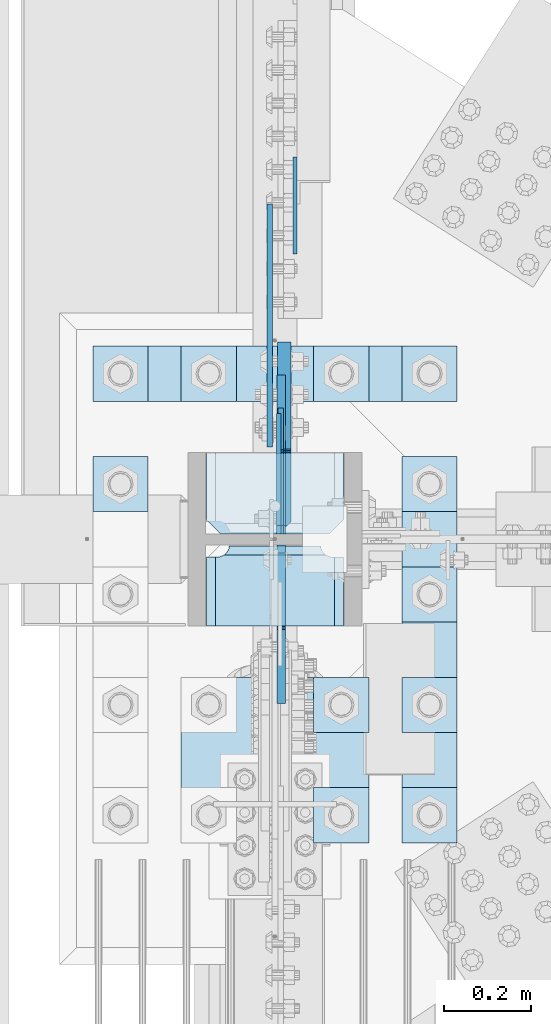
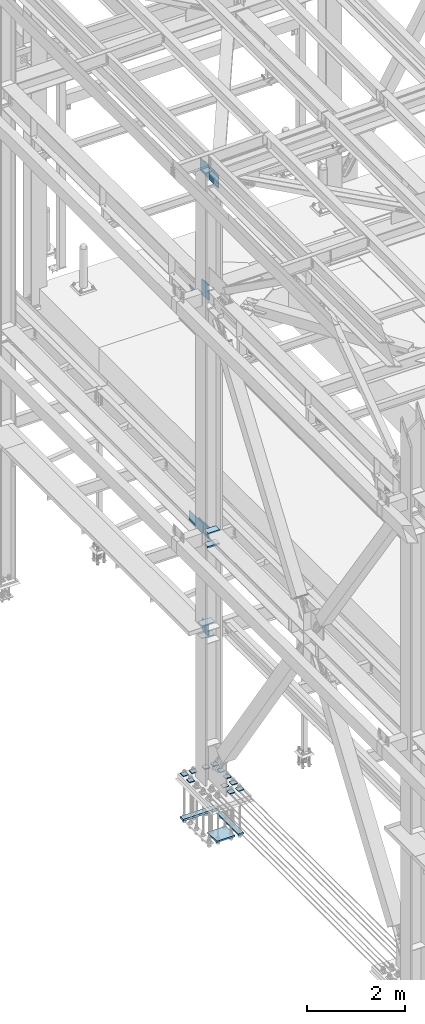
# One storey, part 3365 of 3843: 25 plates, 4 elements without a shape of their own.
"""IFC2X3 building model written with IfcOpenShell, lengths in millimetres."""

from ifc_helpers import new_model, si_unit, frame, origin_with_axes, place, context, subcontext, project, spatial, faceted_brep, material, type_object, element, aggregate, save


model = new_model("IFC2X3")

# Units and contexts
model_context = context("Model", 3, precision=1e-05, world=origin_with_axes())
body_context = subcontext(model_context, "Body", "Model", "MODEL_VIEW")
ifc_project = project(units=[si_unit("LENGTHUNIT", "METRE", prefix="MILLI"), si_unit("AREAUNIT", "SQUARE_METRE"), si_unit("VOLUMEUNIT", "CUBIC_METRE"), si_unit("MASSUNIT", "GRAM", prefix="KILO"), si_unit("TIMEUNIT", "SECOND"), si_unit("PLANEANGLEUNIT", "RADIAN"), si_unit("SOLIDANGLEUNIT", "STERADIAN"), si_unit("THERMODYNAMICTEMPERATUREUNIT", "DEGREE_CELSIUS"), si_unit("LUMINOUSINTENSITYUNIT", "LUMEN")], contexts=[model_context])

# Site, building, storey
site_placement = place(None, origin_with_axes())
site = spatial("IfcSite", under=ifc_project, at=site_placement, CompositionType="ELEMENT")
building_placement = place(site_placement, origin_with_axes())
building = spatial("IfcBuilding", under=site, at=building_placement, Name="Undefined", CompositionType="ELEMENT")
storey_placement = place(building_placement, origin_with_axes())
storey = spatial("IfcBuildingStorey", under=building, at=storey_placement, Name="Undefined", CompositionType="ELEMENT", Elevation=0.0)

# Assembly, plates
assembly_1_placement = place(storey_placement, origin_with_axes())
assembly_1 = element("IfcElementAssembly", 1, at=assembly_1_placement, inside=storey, Name="COLUMN", AssemblyPlace="NOTDEFINED", PredefinedType="RIGID_FRAME")
ifc_material = material(Name="STEEL/A572-50")
plate_type_1 = type_object("IfcPlateType", PredefinedType="NOTDEFINED")
plate_1_placement = place(assembly_1_placement, frame((36734.75, 75825.35, 33688.3375), z_axis=(-1.0, 0.0, 0.0), x_axis=(0.0, -1.0, 0.0)))
plate_1 = element("IfcPlate", 2, at=plate_1_placement, type_object=plate_type_1, material=ifc_material, Name="PLATE", context=body_context, shape_type="Brep", body=[
    faceted_brep([(0.0, -4.76249999999709, 0.0), (0.0, -4.76249999785796, 317.500000005042), (0.0, 4.76250000210712, 317.50000000505), (0.0, 4.76249999999709, 0.0), (150.81249847413, -4.76249999999709, 317.5), (150.81249847413, 4.76249999999709, 317.5), (184.150000000009, -4.76249999999709, 284.162498474121), (184.150000000009, 4.76249999999709, 284.162498474121), (184.150000000009, -4.76249999999709, 33.3375015258789), (184.150000000009, 4.76249999999709, 33.3375015258789), (150.81249847413, -4.76249999999709, 0.0), (150.81249847413, 4.76249999999709, 0.0)], [[[0, 1, 2, 3]], [[1, 4, 5, 2]], [[4, 6, 7, 5]], [[6, 8, 9, 7]], [[8, 10, 11, 9]], [[10, 0, 3, 11]], [[5, 7, 9, 11, 3, 2]], [[10, 8, 6, 4, 1, 0]]]),
])
plate_2_placement = place(assembly_1_placement, frame((36734.75, 75825.35, 34002.6625), z_axis=(-1.0, 0.0, 0.0), x_axis=(0.0, -1.0, 0.0)))
plate_2 = element("IfcPlate", 3, at=plate_2_placement, type_object=plate_type_1, material=ifc_material, Name="PLATE", context=body_context, shape_type="Brep", body=[
    faceted_brep([(0.0, -4.76249999999709, 0.0), (0.0, -4.76249999785796, 317.500000005042), (0.0, 4.76250000210712, 317.50000000505), (0.0, 4.76249999999709, 0.0), (150.81249847413, -4.76249999999709, 317.5), (150.81249847413, 4.76249999999709, 317.5), (184.150000000009, -4.76249999999709, 284.162498474121), (184.150000000009, 4.76249999999709, 284.162498474121), (184.150000000009, -4.76249999999709, 33.3375015258789), (184.150000000009, 4.76249999999709, 33.3375015258789), (150.81249847413, -4.76249999999709, 0.0), (150.81249847413, 4.76249999999709, 0.0)], [[[0, 1, 2, 3]], [[1, 4, 5, 2]], [[4, 6, 7, 5]], [[6, 8, 9, 7]], [[8, 10, 11, 9]], [[10, 0, 3, 11]], [[5, 7, 9, 11, 3, 2]], [[10, 8, 6, 4, 1, 0]]]),
])
plate_type_2 = type_object("IfcPlateType", PredefinedType="NOTDEFINED")
plate_3_placement = place(assembly_1_placement, frame((36588.7000000954, 75641.2, 42049.7), z_axis=(0.0, 0.707106781186548, 0.707106781186548), x_axis=(5.70000238222118e-08, 0.707106781186546, -0.707106781186546)))
plate_3 = element("IfcPlate", 4, at=plate_3_placement, type_object=plate_type_2, material=ifc_material, Name="PLATE", context=body_context, shape_type="Brep", body=[
    faceted_brep([(0.0, -6.3499999046162, 0.0), (-258.182363479495, -6.34999999999854, 258.182363479486), (-258.182363479495, 6.34999999999854, 258.182363479486), (7.27595761418343e-12, 6.3499999046162, 0.0), (-258.18236347936, -6.34999999999854, 285.123131842716), (-258.18236347936, 6.34999999999854, 285.123131842716), (-139.755235882103, -6.34999999999854, 403.550259439973), (-139.755235882103, 6.34999999999854, 403.550259439973), (-133.020043656483, -6.34999999999854, 396.815067214353), (-133.020043656483, 6.34999999999854, 396.815067214353), (-128.899867188344, -6.34999999999854, 394.062053313872), (-128.899867188344, 6.34999999999854, 394.062053313872), (-124.039787670305, -6.34999999999854, 393.095323391288), (-124.039787670305, 6.34999999999854, 393.095323391288), (-119.179708152273, -6.34999999999854, 394.062053313872), (-119.179708152273, 6.34999999999854, 394.062053313872), (-115.059531684126, -6.34999999999854, 396.815067214353), (-115.059531684126, 6.34999999999854, 396.815067214353), (-51.6364726937954, -6.34999999999854, 460.238126204684), (-51.6364726937954, 6.34999999999854, 460.238126204684), (226.751467058011, -6.34999999999854, 181.850186452881), (226.751467058011, 6.34999999999854, 181.850186452881), (154.348152081502, -6.34999999999854, 109.446871476364), (154.348152081502, 6.34999999999854, 109.446871476364), (145.367895960471, -6.34999999999854, 118.427127597388), (145.367895960471, 6.34999999999854, 118.427127597388), (26.9407683632217, -6.34999999999854, 1.30967237055302e-10), (26.9407683632217, 6.34999999999854, 1.30967237055302e-10)], [[[0, 1, 2, 3]], [[1, 4, 5, 2]], [[4, 6, 7, 5]], [[6, 8, 9, 7]], [[8, 10, 11, 9]], [[10, 12, 13, 11]], [[12, 14, 15, 13]], [[14, 16, 17, 15]], [[16, 18, 19, 17]], [[18, 20, 21, 19]], [[20, 22, 23, 21]], [[22, 24, 25, 23]], [[24, 26, 27, 25]], [[26, 0, 3, 27]], [[5, 7, 9, 11, 13, 15, 17, 19, 21, 23, 25, 27, 3, 2]], [[26, 24, 22, 20, 18, 16, 14, 12, 10, 8, 6, 4, 1, 0]]]),
])
plate_type_3 = type_object("IfcPlateType", PredefinedType="NOTDEFINED")
plate_4_placement = place(assembly_1_placement, frame((36415.6625, 75429.2687, 36085.4625), z_axis=(1.0, 0.0, 0.0), x_axis=(0.0, 1.0, 0.0)))
plate_4 = element("IfcPlate", 5, at=plate_4_placement, type_object=plate_type_3, material=ifc_material, Name="PLATE", context=body_context, shape_type="Brep", body=[
    faceted_brep([(169.7353359673, 6.12970259824215, 50.1051604685563), (163.413638768514, 17.0792088240414, 43.7834632697632), (163.192342336726, 17.4625000000015, 43.3491445679101), (163.192342336726, 17.4625000000015, 277.325855432093), (163.413638768514, 17.0792088240414, 276.89153673024), (169.7353359673, 6.12970259824215, 270.569839531447), (177.701139149976, -7.66747323724849, 266.511060084209), (183.356300047686, -17.4625000000015, 265.61537059048), (183.356300047686, -17.4625000000015, 55.059629409523), (177.701139149976, -7.66747323724849, 54.1639399157939), (0.0, 17.4625000000015, 297.336542336721), (0.0, -17.4625000000015, 317.500500047689), (157.956299237063, -17.4625000000015, 317.500500047689), (157.956299237063, 17.4625000000015, 297.336542336721), (157.956299237063, 17.4625000000015, 23.3384576632816), (157.956299237063, -17.4625000000015, 3.17449995231436), (0.0, -17.4625000000015, 3.17449995232164), (0.0, 17.4625000000015, 23.3384576632816), (157.956299237063, -17.4625000000015, 293.687500762942), (157.956299237063, 17.4625000000015, 293.687500762942), (159.354859321276, -17.4625000000015, 284.857339912916), (159.354859321276, 17.4625000000015, 284.857339912916), (163.413638768514, -17.4625000000015, 276.89153673024), (169.7353359673, -17.4625000000015, 270.569839531447), (177.701139149984, -17.4625000000015, 266.511060084209), (177.701139149984, -17.4625000000015, 54.1639399157939), (169.7353359673, -17.4625000000015, 50.1051604685563), (163.413638768514, -17.4625000000015, 43.7834632697632), (159.354859321276, -17.4625000000015, 35.8176600870866), (159.354859321276, 17.4625000000015, 35.8176600870866), (157.956299237063, -17.4625000000015, 26.9874992370605), (157.956299237063, 17.4625000000015, 26.9874992370605)], [[[0, 1, 2, 3, 4, 5, 6, 7, 8, 9]], [[10, 11, 12, 13]], [[14, 15, 16, 17]], [[17, 16, 11, 10]], [[18, 19, 13, 12]], [[18, 20, 21, 19]], [[21, 20, 22, 4, 3]], [[22, 23, 5, 4]], [[23, 24, 6, 5]], [[24, 7, 6]], [[25, 9, 8]], [[25, 26, 0, 9]], [[26, 27, 1, 0]], [[27, 28, 29, 2, 1]], [[28, 30, 31, 29]], [[31, 30, 15, 14]], [[29, 31, 14, 17, 10, 13, 19, 21, 3, 2]], [[15, 30, 28, 27, 26, 25, 8, 7, 24, 23, 22, 20, 18, 12, 11, 16]]]),
])
plate_5_placement = place(assembly_1_placement, frame((36415.6625, 75429.2687, 36418.8375), z_axis=(1.0, 0.0, 0.0), x_axis=(0.0, 1.0, 0.0)))
plate_5 = element("IfcPlate", 6, at=plate_5_placement, type_object=plate_type_3, material=ifc_material, Name="PLATE", context=body_context, shape_type="Brep", body=[
    faceted_brep([(169.7353359673, 6.12970259824215, 50.1051604685563), (163.413638768514, 17.0792088240414, 43.7834632697632), (163.192342336726, 17.4625000000015, 43.3491445679101), (163.192342336726, 17.4625000000015, 277.325855432093), (163.413638768514, 17.0792088240414, 276.89153673024), (169.7353359673, 6.12970259824215, 270.569839531447), (177.701139149976, -7.66747323724849, 266.511060084209), (183.356300047686, -17.4625000000015, 265.61537059048), (183.356300047686, -17.4625000000015, 55.059629409523), (177.701139149976, -7.66747323724849, 54.1639399157939), (0.0, 17.4625000000015, 297.336542336721), (0.0, -17.4625000000015, 317.500500047689), (157.956299237063, -17.4625000000015, 317.500500047689), (157.956299237063, 17.4625000000015, 297.336542336721), (157.956299237063, 17.4625000000015, 23.3384576632816), (157.956299237063, -17.4625000000015, 3.17449995231436), (0.0, -17.4625000000015, 3.17449995232164), (0.0, 17.4625000000015, 23.3384576632816), (157.956299237063, -17.4625000000015, 293.687500762942), (157.956299237063, 17.4625000000015, 293.687500762942), (159.354859321276, -17.4625000000015, 284.857339912916), (159.354859321276, 17.4625000000015, 284.857339912916), (163.413638768514, -17.4625000000015, 276.89153673024), (169.7353359673, -17.4625000000015, 270.569839531447), (177.701139149984, -17.4625000000015, 266.511060084209), (177.701139149984, -17.4625000000015, 54.1639399157939), (169.7353359673, -17.4625000000015, 50.1051604685563), (163.413638768514, -17.4625000000015, 43.7834632697632), (159.354859321276, -17.4625000000015, 35.8176600870866), (159.354859321276, 17.4625000000015, 35.8176600870866), (157.956299237063, -17.4625000000015, 26.9874992370605), (157.956299237063, 17.4625000000015, 26.9874992370605)], [[[0, 1, 2, 3, 4, 5, 6, 7, 8, 9]], [[10, 11, 12, 13]], [[14, 15, 16, 17]], [[17, 16, 11, 10]], [[18, 19, 13, 12]], [[18, 20, 21, 19]], [[21, 20, 22, 4, 3]], [[22, 23, 5, 4]], [[23, 24, 6, 5]], [[24, 7, 6]], [[25, 9, 8]], [[25, 26, 0, 9]], [[26, 27, 1, 0]], [[27, 28, 29, 2, 1]], [[28, 30, 31, 29]], [[31, 30, 15, 14]], [[29, 31, 14, 17, 10, 13, 19, 21, 3, 2]], [[15, 30, 28, 27, 26, 25, 8, 7, 24, 23, 22, 20, 18, 12, 11, 16]]]),
])

# Assembly, plate
assembly_2_placement = place(storey_placement, origin_with_axes())
assembly_2 = element("IfcElementAssembly", 7, at=assembly_2_placement, inside=storey, Name="BEAM", AssemblyPlace="NOTDEFINED", PredefinedType="RIGID_FRAME")
plate_type_4 = type_object("IfcPlateType", PredefinedType="NOTDEFINED")
plate_6_placement = place(assembly_2_placement, frame((36622.0375, 76284.7289773786, 41925.875), z_axis=(0.0, 0.707106781186548, 0.707106781186548), x_axis=(5.70000238222118e-08, 0.707106781186546, -0.707106781186546)))
plate_6 = element("IfcPlate", 8, at=plate_6_placement, type_object=plate_type_4, material=ifc_material, Name="PLATE", context=body_context, shape_type="Brep", body=[
    faceted_brep([(0.0, -4.76249999999709, 0.0), (157.726597423803, -4.76249999999709, 157.726601438866), (157.726597423803, 4.76249999999709, 157.726601438866), (0.0, 4.76249999999709, 0.0), (188.387110059113, -4.76249999999709, 127.066089584019), (188.387110059113, 4.76249999999709, 127.066089584019), (188.387111679331, -4.76249999999709, 1.09139364212751e-10), (188.387111679331, 4.76249999999709, 1.09139364212751e-10)], [[[0, 1, 2, 3]], [[1, 4, 5, 2]], [[4, 6, 7, 5]], [[6, 0, 3, 7]], [[5, 7, 3, 2]], [[6, 4, 1, 0]]]),
])
aggregate(assembly_2, [plate_6])

# Plate
plate_type_5 = type_object("IfcPlateType", PredefinedType="NOTDEFINED")
plate_7_placement = place(assembly_1_placement, frame((36590.287500451, 75641.2, 45088.1750027922), z_axis=(0.0, 0.707106781186548, 0.707106781186548), x_axis=(5.70000238222118e-08, 0.707106781186546, -0.707106781186546)))
plate_7 = element("IfcPlate", 9, at=plate_7_placement, type_object=plate_type_5, material=ifc_material, Name="PLATE", context=body_context, shape_type="Brep", body=[
    faceted_brep([(0.0, -9.52500000000146, 0.0), (-206.545892322774, -9.52500000000146, 206.545889244429), (-206.545892322774, 9.52500000000146, 206.545889244429), (0.0, 9.52500000000146, 0.0), (-206.545892322807, -9.52500000000146, 233.486657406793), (-206.545892322807, 9.52500000000146, 233.486657406793), (-87.5574981562204, -9.52500000000146, 352.475049513436), (-87.5574981562204, 9.52500000000146, 352.475049513436), (-83.4373216675631, -9.52500000000146, 349.722035643659), (-83.4373216675631, 9.52500000000146, 349.722035643659), (-78.5772421423244, -9.52500000000146, 348.755305757295), (-78.5772421423244, 9.52500000000146, 348.755305757295), (-73.7171626314957, -9.52500000000146, 349.722035716099), (-73.7171626314957, 9.52500000000146, 349.722035716099), (-69.5969861838676, -9.52500000000146, 352.47504964727), (-69.5969861838676, 9.52500000000146, 352.47504964727), (47.1463462352222, -9.52500000000146, 469.218383806307), (47.1463462352222, 9.52500000000146, 469.218383806307), (271.652750933881, -9.52500000000146, 244.711982453664), (271.652750933881, 9.52500000000146, 244.711982453664), (26.9407683632344, -9.52499999999964, 2.03726813197136e-10), (26.9407683632344, 9.52499999999964, 2.03726813197136e-10)], [[[0, 1, 2, 3]], [[1, 4, 5, 2]], [[4, 6, 7, 5]], [[6, 8, 9, 7]], [[8, 10, 11, 9]], [[10, 12, 13, 11]], [[12, 14, 15, 13]], [[14, 16, 17, 15]], [[16, 18, 19, 17]], [[18, 20, 21, 19]], [[20, 0, 3, 21]], [[5, 7, 9, 11, 13, 15, 17, 19, 21, 3, 2]], [[20, 18, 16, 14, 12, 10, 8, 6, 4, 1, 0]]]),
])

plate_8_placement = place(assembly_1_placement, frame((36590.2875004394, 75615.8, 45088.175002792), z_axis=(0.0, -0.707106781186682, 0.707106781186413), x_axis=(0.0, -0.707106781186548, -0.707106781186548)))
plate_8 = element("IfcPlate", 10, at=plate_8_placement, type_object=plate_type_5, material=ifc_material, Name="PLATE", context=body_context, shape_type="Brep", body=[
    faceted_brep([(0.0, -9.52500000000146, 0.0), (-206.545892322774, -9.52500000000146, 206.545889244429), (-206.545892322774, 9.52500000000146, 206.545889244429), (0.0, 9.52500000000146, 0.0), (-206.545892322807, -9.52500000000146, 233.486657406793), (-206.545892322807, 9.52500000000146, 233.486657406793), (-87.5574981562204, -9.52500000000146, 352.475049513436), (-87.5574981562204, 9.52500000000146, 352.475049513436), (-83.4373216675631, -9.52500000000146, 349.722035643659), (-83.4373216675631, 9.52500000000146, 349.722035643659), (-78.5772421423244, -9.52500000000146, 348.755305757295), (-78.5772421423244, 9.52500000000146, 348.755305757295), (-73.7171626314957, -9.52500000000146, 349.722035716099), (-73.7171626314957, 9.52500000000146, 349.722035716099), (-69.5969861838676, -9.52500000000146, 352.47504964727), (-69.5969861838676, 9.52500000000146, 352.47504964727), (47.1463462352222, -9.52500000000146, 469.218383806307), (47.1463462352222, 9.52500000000146, 469.218383806307), (271.652750933881, -9.52500000000146, 244.711982453664), (271.652750933881, 9.52500000000146, 244.711982453664), (26.9407683632344, -9.52499999999964, 2.03726813197136e-10), (26.9407683632344, 9.52499999999964, 2.03726813197136e-10)], [[[0, 1, 2, 3]], [[1, 4, 5, 2]], [[4, 6, 7, 5]], [[6, 8, 9, 7]], [[8, 10, 11, 9]], [[10, 12, 13, 11]], [[12, 14, 15, 13]], [[14, 16, 17, 15]], [[16, 18, 19, 17]], [[18, 20, 21, 19]], [[20, 0, 3, 21]], [[5, 7, 9, 11, 13, 15, 17, 19, 21, 3, 2]], [[20, 18, 16, 14, 12, 10, 8, 6, 4, 1, 0]]]),
])

# Assembly, plate
assembly_3_placement = place(storey_placement, origin_with_axes())
assembly_3 = element("IfcElementAssembly", 11, at=assembly_3_placement, inside=storey, Name="BEAM", AssemblyPlace="NOTDEFINED", PredefinedType="RIGID_FRAME")
plate_type_6 = type_object("IfcPlateType", PredefinedType="NOTDEFINED")
plate_9_placement = place(assembly_3_placement, frame((36564.09375, 76400.025012207, 36385.5), z_axis=(0.0, -1.0, 0.0), x_axis=(0.0, 0.0, -1.0)))
plate_9 = element("IfcPlate", 12, at=plate_9_placement, type_object=plate_type_6, material=ifc_material, Name="PLATE", context=body_context, shape_type="Brep", body=[
    faceted_brep([(0.0, -6.3499999046162, 0.0), (-1.27693056128919e-09, -6.34999999999854, 558.800000006726), (0.0, 6.35000000000036, 558.799999999988), (7.27595761418343e-12, 6.3499999046162, 0.0), (241.300003051758, -6.34999999999854, 558.800012207037), (241.300003051758, 6.34999999999854, 558.800012207037), (241.300003051758, -6.34999999999854, 0.0), (241.300003051758, 6.34999999999854, 0.0)], [[[0, 1, 2, 3]], [[1, 4, 5, 2]], [[4, 6, 7, 5]], [[6, 0, 3, 7]], [[5, 7, 3, 2]], [[6, 4, 1, 0]]]),
])
aggregate(assembly_3, [plate_9])

# Plate
plate_type_7 = type_object("IfcPlateType", PredefinedType="NOTDEFINED")
plate_10_placement = place(assembly_1_placement, frame((36597.43125, 75641.2, 36401.375), z_axis=(0.0, 1.0, 0.0), x_axis=(0.0, 0.0, -1.0)))
plate_10 = element("IfcPlate", 13, at=plate_10_placement, type_object=plate_type_7, material=ifc_material, Name="PLATE", context=body_context, shape_type="Brep", body=[
    faceted_brep([(298.449999999997, -15.875, 28.5749999999971), (0.0, -15.875, 28.5750007629395), (0.0, -6.34999999999854, 19.0499992370605), (19.0500015258731, 12.6999999999971, 0.0), (279.400000762937, 12.6999999999971, 0.0), (298.449999999997, -6.34999923706346, 19.0499992370605), (0.0, -15.875, 187.325000000004), (0.0, 15.875, 187.325000000004), (0.0, 15.875, 19.0499992370605), (3.17500019070576, -15.875, 187.325000000004), (3.17500019070576, 15.875, 187.325000000004), (8.03507970875216, -15.875, 188.291729922596), (8.03507970875216, 15.875, 188.291729922596), (12.1552561769058, -15.875, 191.044743823069), (12.1552561769058, 15.875, 191.044743823069), (14.908270077387, -15.875, 195.164920291223), (14.908270077387, 15.875, 195.164920291223), (15.8749999999709, -15.875, 200.02499980927), (15.8749999999709, 15.875, 200.02499980927), (15.875, -15.875, 441.325012207031), (15.875, 15.875, 441.325012207031), (257.175003051758, -15.875, 441.325012207031), (257.175003051758, 15.875, 441.325012207031), (257.175003051729, -15.875, 200.02499980927), (257.175003051729, 15.875, 200.02499980927), (258.14173297432, -15.875, 195.164920291223), (258.14173297432, 15.875, 195.164920291223), (260.894746874794, -15.875, 191.044743823069), (260.894746874794, 15.875, 191.044743823069), (265.014923342947, -15.875, 188.291729922596), (265.014923342947, 15.875, 188.291729922596), (269.875002860994, -15.875, 187.325000000004), (269.875002860994, 15.875, 187.325000000004), (298.449999999997, -15.875, 187.325000000004), (298.449999999997, 15.875, 187.325000000004), (298.449999999997, 15.875, 19.0499992370605), (279.400000762937, 15.875, 0.0), (19.0500015258804, 15.875, 0.0)], [[[0, 1, 2, 3, 4, 5]], [[6, 7, 8, 2, 1]], [[6, 9, 10, 7]], [[9, 11, 12, 10]], [[11, 13, 14, 12]], [[13, 15, 16, 14]], [[15, 17, 18, 16]], [[17, 19, 20, 18]], [[19, 21, 22, 20]], [[21, 23, 24, 22]], [[23, 25, 26, 24]], [[25, 27, 28, 26]], [[27, 29, 30, 28]], [[29, 31, 32, 30]], [[31, 33, 34, 32]], [[35, 34, 33, 0, 5]], [[36, 35, 5, 4]], [[37, 36, 4, 3]], [[8, 37, 3, 2]], [[10, 12, 14, 16, 18, 20, 22, 24, 26, 28, 30, 32, 34, 35, 36, 37, 8, 7]], [[33, 31, 29, 27, 25, 23, 21, 19, 17, 15, 13, 11, 9, 6, 1, 0]]]),
])

plate_type_8 = type_object("IfcPlateType", PredefinedType="NOTDEFINED")
plate_11_placement = place(assembly_1_placement, frame((36584.73125, 75641.2, 33712.1500027914), z_axis=(0.0, 0.707106781186548, 0.707106781186548), x_axis=(5.70000238222118e-08, 0.707106781186546, -0.707106781186546)))
plate_11 = element("IfcPlate", 14, at=plate_11_placement, type_object=plate_type_8, material=ifc_material, Name="PLATE", context=body_context, shape_type="Brep", body=[
    faceted_brep([(0.0, -4.76249999999709, 0.0), (-188.585379946875, -4.76249999999709, 188.585377136231), (-188.585379946875, 4.76249999999709, 188.585377136231), (0.0, 4.76249999999709, 0.0), (-188.585379946759, -4.76249999999709, 215.526145298725), (-188.585379946759, 4.76249999999709, 215.526145298725), (-6.73518993152538, -4.76249999999709, 397.376334478104), (-6.73518993152538, 4.76249999999709, 397.376334478104), (208.790958579193, -4.76249999999709, 181.850189179575), (208.790958579193, 4.76249999999709, 181.850189179575), (26.9407683631998, -4.76249999999709, 1.30967237055302e-10), (26.9407683631998, 4.76249999999709, 1.30967237055302e-10)], [[[0, 1, 2, 3]], [[1, 4, 5, 2]], [[4, 6, 7, 5]], [[6, 8, 9, 7]], [[8, 10, 11, 9]], [[10, 0, 3, 11]], [[5, 7, 9, 11, 3, 2]], [[10, 8, 6, 4, 1, 0]]]),
])

aggregate(assembly_1, [plate_3, plate_7, plate_8, plate_4, plate_5, plate_10, plate_1, plate_2, plate_11])

# Assembly, plates
assembly_4_placement = place(storey_placement, origin_with_axes())
assembly_4 = element("IfcElementAssembly", 15, at=assembly_4_placement, inside=storey, Name="TEMPLATE", AssemblyPlace="NOTDEFINED", PredefinedType="RIGID_FRAME")
plate_type_9 = type_object("IfcPlateType", PredefinedType="NOTDEFINED")
plate_12_placement = place(assembly_4_placement, frame((36868.1, 75057.0, 30172.025), z_axis=(0.0, -1.0, 0.0), x_axis=(1.0, 0.0, 0.0)))
plate_12 = element("IfcPlate", 16, at=plate_12_placement, type_object=plate_type_9, material=ifc_material, Name="Washer Plate", context=body_context, shape_type="Brep", body=[
    faceted_brep([(0.0, -9.52500000000146, 0.0), (0.0, -9.52499999999418, 127.0), (0.0, 9.52499999999418, 127.0), (0.0, 9.52500000000146, 0.0), (127.0, -9.52500000000146, 127.0), (127.0, 9.52500000000146, 127.0), (127.0, -9.52500000000146, 0.0), (127.0, 9.52500000000146, 0.0)], [[[0, 1, 2, 3]], [[1, 4, 5, 2]], [[4, 6, 7, 5]], [[6, 0, 3, 7]], [[5, 7, 3, 2]], [[6, 4, 1, 0]]]),
])
plate_13_placement = place(assembly_4_placement, frame((36868.1, 75311.0, 30172.025), z_axis=(0.0, -1.0, 0.0), x_axis=(1.0, 0.0, 0.0)))
plate_13 = element("IfcPlate", 17, at=plate_13_placement, type_object=plate_type_9, material=ifc_material, Name="Washer Plate", context=body_context, shape_type="Brep", body=[
    faceted_brep([(0.0, -9.52500000000146, 0.0), (0.0, -9.52499999999418, 127.0), (0.0, 9.52499999999418, 127.0), (0.0, 9.52500000000146, 0.0), (127.0, -9.52500000000146, 127.0), (127.0, 9.52500000000146, 127.0), (127.0, -9.52500000000146, 0.0), (127.0, 9.52500000000146, 0.0)], [[[0, 1, 2, 3]], [[1, 4, 5, 2]], [[4, 6, 7, 5]], [[6, 0, 3, 7]], [[5, 7, 3, 2]], [[6, 4, 1, 0]]]),
])
plate_14_placement = place(assembly_4_placement, frame((36868.1, 75565.0, 30172.025), z_axis=(0.0, -1.0, 0.0), x_axis=(1.0, 0.0, 0.0)))
plate_14 = element("IfcPlate", 18, at=plate_14_placement, type_object=plate_type_9, material=ifc_material, Name="Washer Plate", context=body_context, shape_type="Brep", body=[
    faceted_brep([(0.0, -9.52500000000146, 0.0), (0.0, -9.52499999999418, 127.0), (0.0, 9.52499999999418, 127.0), (0.0, 9.52500000000146, 0.0), (127.0, -9.52500000000146, 127.0), (127.0, 9.52500000000146, 127.0), (127.0, -9.52500000000146, 0.0), (127.0, 9.52500000000146, 0.0)], [[[0, 1, 2, 3]], [[1, 4, 5, 2]], [[4, 6, 7, 5]], [[6, 0, 3, 7]], [[5, 7, 3, 2]], [[6, 4, 1, 0]]]),
])
plate_15_placement = place(assembly_4_placement, frame((36868.1, 75819.0, 30172.025), z_axis=(0.0, -1.0, 0.0), x_axis=(1.0, 0.0, 0.0)))
plate_15 = element("IfcPlate", 19, at=plate_15_placement, type_object=plate_type_9, material=ifc_material, Name="Washer Plate", context=body_context, shape_type="Brep", body=[
    faceted_brep([(0.0, -9.52500000000146, 0.0), (0.0, -9.52499999999418, 127.0), (0.0, 9.52499999999418, 127.0), (0.0, 9.52500000000146, 0.0), (127.0, -9.52500000000146, 127.0), (127.0, 9.52500000000146, 127.0), (127.0, -9.52500000000146, 0.0), (127.0, 9.52500000000146, 0.0)], [[[0, 1, 2, 3]], [[1, 4, 5, 2]], [[4, 6, 7, 5]], [[6, 0, 3, 7]], [[5, 7, 3, 2]], [[6, 4, 1, 0]]]),
])
plate_16_placement = place(assembly_4_placement, frame((36868.1, 76073.0, 30172.025), z_axis=(0.0, -1.0, 0.0), x_axis=(1.0, 0.0, 0.0)))
plate_16 = element("IfcPlate", 20, at=plate_16_placement, type_object=plate_type_9, material=ifc_material, Name="Washer Plate", context=body_context, shape_type="Brep", body=[
    faceted_brep([(0.0, -9.52500000000146, 0.0), (0.0, -9.52499999999418, 127.0), (0.0, 9.52499999999418, 127.0), (0.0, 9.52500000000146, 0.0), (127.0, -9.52500000000146, 127.0), (127.0, 9.52500000000146, 127.0), (127.0, -9.52500000000146, 0.0), (127.0, 9.52500000000146, 0.0)], [[[0, 1, 2, 3]], [[1, 4, 5, 2]], [[4, 6, 7, 5]], [[6, 0, 3, 7]], [[5, 7, 3, 2]], [[6, 4, 1, 0]]]),
])
plate_17_placement = place(assembly_4_placement, frame((36664.9, 75057.0, 30172.025), z_axis=(0.0, -1.0, 0.0), x_axis=(1.0, 0.0, 0.0)))
plate_17 = element("IfcPlate", 21, at=plate_17_placement, type_object=plate_type_9, material=ifc_material, Name="Washer Plate", context=body_context, shape_type="Brep", body=[
    faceted_brep([(0.0, -9.52500000000146, 0.0), (0.0, -9.52499999999418, 127.0), (0.0, 9.52499999999418, 127.0), (0.0, 9.52500000000146, 0.0), (127.0, -9.52500000000146, 127.0), (127.0, 9.52500000000146, 127.0), (127.0, -9.52500000000146, 0.0), (127.0, 9.52500000000146, 0.0)], [[[0, 1, 2, 3]], [[1, 4, 5, 2]], [[4, 6, 7, 5]], [[6, 0, 3, 7]], [[5, 7, 3, 2]], [[6, 4, 1, 0]]]),
])
plate_18_placement = place(assembly_4_placement, frame((36664.9, 75311.0, 30172.025), z_axis=(0.0, -1.0, 0.0), x_axis=(1.0, 0.0, 0.0)))
plate_18 = element("IfcPlate", 22, at=plate_18_placement, type_object=plate_type_9, material=ifc_material, Name="Washer Plate", context=body_context, shape_type="Brep", body=[
    faceted_brep([(0.0, -9.52500000000146, 0.0), (0.0, -9.52499999999418, 127.0), (0.0, 9.52499999999418, 127.0), (0.0, 9.52500000000146, 0.0), (127.0, -9.52500000000146, 127.0), (127.0, 9.52500000000146, 127.0), (127.0, -9.52500000000146, 0.0), (127.0, 9.52500000000146, 0.0)], [[[0, 1, 2, 3]], [[1, 4, 5, 2]], [[4, 6, 7, 5]], [[6, 0, 3, 7]], [[5, 7, 3, 2]], [[6, 4, 1, 0]]]),
])
plate_19_placement = place(assembly_4_placement, frame((36664.9, 76073.0, 30172.025), z_axis=(0.0, -1.0, 0.0), x_axis=(1.0, 0.0, 0.0)))
plate_19 = element("IfcPlate", 23, at=plate_19_placement, type_object=plate_type_9, material=ifc_material, Name="Washer Plate", context=body_context, shape_type="Brep", body=[
    faceted_brep([(0.0, -9.52500000000146, 0.0), (0.0, -9.52499999999418, 127.0), (0.0, 9.52499999999418, 127.0), (0.0, 9.52500000000146, 0.0), (127.0, -9.52500000000146, 127.0), (127.0, 9.52500000000146, 127.0), (127.0, -9.52500000000146, 0.0), (127.0, 9.52500000000146, 0.0)], [[[0, 1, 2, 3]], [[1, 4, 5, 2]], [[4, 6, 7, 5]], [[6, 0, 3, 7]], [[5, 7, 3, 2]], [[6, 4, 1, 0]]]),
])
plate_20_placement = place(assembly_4_placement, frame((36360.1, 76073.0, 30172.025), z_axis=(0.0, -1.0, 0.0), x_axis=(1.0, 0.0, 0.0)))
plate_20 = element("IfcPlate", 24, at=plate_20_placement, type_object=plate_type_9, material=ifc_material, Name="Washer Plate", context=body_context, shape_type="Brep", body=[
    faceted_brep([(0.0, -9.52500000000146, 0.0), (0.0, -9.52499999999418, 127.0), (0.0, 9.52499999999418, 127.0), (0.0, 9.52500000000146, 0.0), (127.0, -9.52500000000146, 127.0), (127.0, 9.52500000000146, 127.0), (127.0, -9.52500000000146, 0.0), (127.0, 9.52500000000146, 0.0)], [[[0, 1, 2, 3]], [[1, 4, 5, 2]], [[4, 6, 7, 5]], [[6, 0, 3, 7]], [[5, 7, 3, 2]], [[6, 4, 1, 0]]]),
])
plate_21_placement = place(assembly_4_placement, frame((36156.9, 75819.0, 30172.025), z_axis=(0.0, -1.0, 0.0), x_axis=(1.0, 0.0, 0.0)))
plate_21 = element("IfcPlate", 25, at=plate_21_placement, type_object=plate_type_9, material=ifc_material, Name="Washer Plate", context=body_context, shape_type="Brep", body=[
    faceted_brep([(0.0, -9.52500000000146, 0.0), (0.0, -9.52499999999418, 127.0), (0.0, 9.52499999999418, 127.0), (0.0, 9.52500000000146, 0.0), (127.0, -9.52500000000146, 127.0), (127.0, 9.52500000000146, 127.0), (127.0, -9.52500000000146, 0.0), (127.0, 9.52500000000146, 0.0)], [[[0, 1, 2, 3]], [[1, 4, 5, 2]], [[4, 6, 7, 5]], [[6, 0, 3, 7]], [[5, 7, 3, 2]], [[6, 4, 1, 0]]]),
])
plate_22_placement = place(assembly_4_placement, frame((36156.9, 76073.0, 30172.025), z_axis=(0.0, -1.0, 0.0), x_axis=(1.0, 0.0, 0.0)))
plate_22 = element("IfcPlate", 26, at=plate_22_placement, type_object=plate_type_9, material=ifc_material, Name="Washer Plate", context=body_context, shape_type="Brep", body=[
    faceted_brep([(0.0, -9.52500000000146, 0.0), (0.0, -9.52499999999418, 127.0), (0.0, 9.52499999999418, 127.0), (0.0, 9.52500000000146, 0.0), (127.0, -9.52500000000146, 127.0), (127.0, 9.52500000000146, 127.0), (127.0, -9.52500000000146, 0.0), (127.0, 9.52500000000146, 0.0)], [[[0, 1, 2, 3]], [[1, 4, 5, 2]], [[4, 6, 7, 5]], [[6, 0, 3, 7]], [[5, 7, 3, 2]], [[6, 4, 1, 0]]]),
])
plate_type_10 = type_object("IfcPlateType", PredefinedType="NOTDEFINED")
plate_23_placement = place(assembly_4_placement, frame((36868.1, 74930.0, 29089.35), z_axis=(0.0, 1.0, 0.0), x_axis=(1.0, 0.0, 0.0)))
plate_23 = element("IfcPlate", 27, at=plate_23_placement, type_object=plate_type_10, material=ifc_material, Name="PLATE", context=body_context, shape_type="Brep", body=[
    faceted_brep([(0.0, -19.0500000000029, 0.0), (-7.27595761418343e-12, -19.0499999999993, 889.0), (-7.27595761418343e-12, 19.0499999999993, 889.0), (0.0, 19.0500000000029, 0.0), (127.0, -19.0499999999993, 889.0), (127.0, 19.0499999999993, 889.0), (127.0, -19.0499999999993, 0.0), (127.0, 19.0499999999993, 0.0)], [[[0, 1, 2, 3]], [[1, 4, 5, 2]], [[4, 6, 7, 5]], [[6, 0, 3, 7]], [[5, 7, 3, 2]], [[6, 4, 1, 0]]]),
])
plate_type_11 = type_object("IfcPlateType", PredefinedType="NOTDEFINED")
plate_24_placement = place(assembly_4_placement, frame((36791.9, 75311.0, 29089.35), z_axis=(-1.0, 0.0, 0.0), x_axis=(0.0, -1.0, 0.0)))
plate_24 = element("IfcPlate", 28, at=plate_24_placement, type_object=plate_type_11, material=ifc_material, Name="PLATE", context=body_context, shape_type="Brep", body=[
    faceted_brep([(0.0, -19.0500000000029, 0.0), (0.0, -19.0499999999993, 431.799987792969), (0.0, 19.0499999999993, 431.799987792969), (0.0, 19.0500000000029, 0.0), (381.0, -19.0499999999993, 431.799987792969), (381.0, 19.0499999999993, 431.799987792969), (381.0, -19.0499999999993, 0.0), (381.0, 19.0499999999993, 0.0)], [[[0, 1, 2, 3]], [[1, 4, 5, 2]], [[4, 6, 7, 5]], [[6, 0, 3, 7]], [[5, 7, 3, 2]], [[6, 4, 1, 0]]]),
])
plate_type_12 = type_object("IfcPlateType", PredefinedType="NOTDEFINED")
plate_25_placement = place(assembly_4_placement, frame((36995.1, 76073.0, 29083.0), z_axis=(-1.0, 0.0, 0.0), x_axis=(0.0, -1.0, 0.0)))
plate_25 = element("IfcPlate", 29, at=plate_25_placement, type_object=plate_type_12, material=ifc_material, Name="PLATE", context=body_context, shape_type="Brep", body=[
    faceted_brep([(0.0, -25.3999996185303, 0.0), (0.0, -25.4000000000015, 838.200012207031), (0.0, 25.4000000000015, 838.200012207031), (0.0, 25.3999996185303, 0.0), (127.0, -25.4000000000015, 838.200012207031), (127.0, 25.4000000000015, 838.200012207031), (127.0, -25.4000000000015, 0.0), (127.0, 25.4000000000015, 0.0)], [[[0, 1, 2, 3]], [[1, 4, 5, 2]], [[4, 6, 7, 5]], [[6, 0, 3, 7]], [[5, 7, 3, 2]], [[6, 4, 1, 0]]]),
])
aggregate(assembly_4, [plate_23, plate_12, plate_13, plate_14, plate_15, plate_16, plate_17, plate_18, plate_19, plate_20, plate_21, plate_22, plate_24, plate_25])

save(model, "model.ifc")
